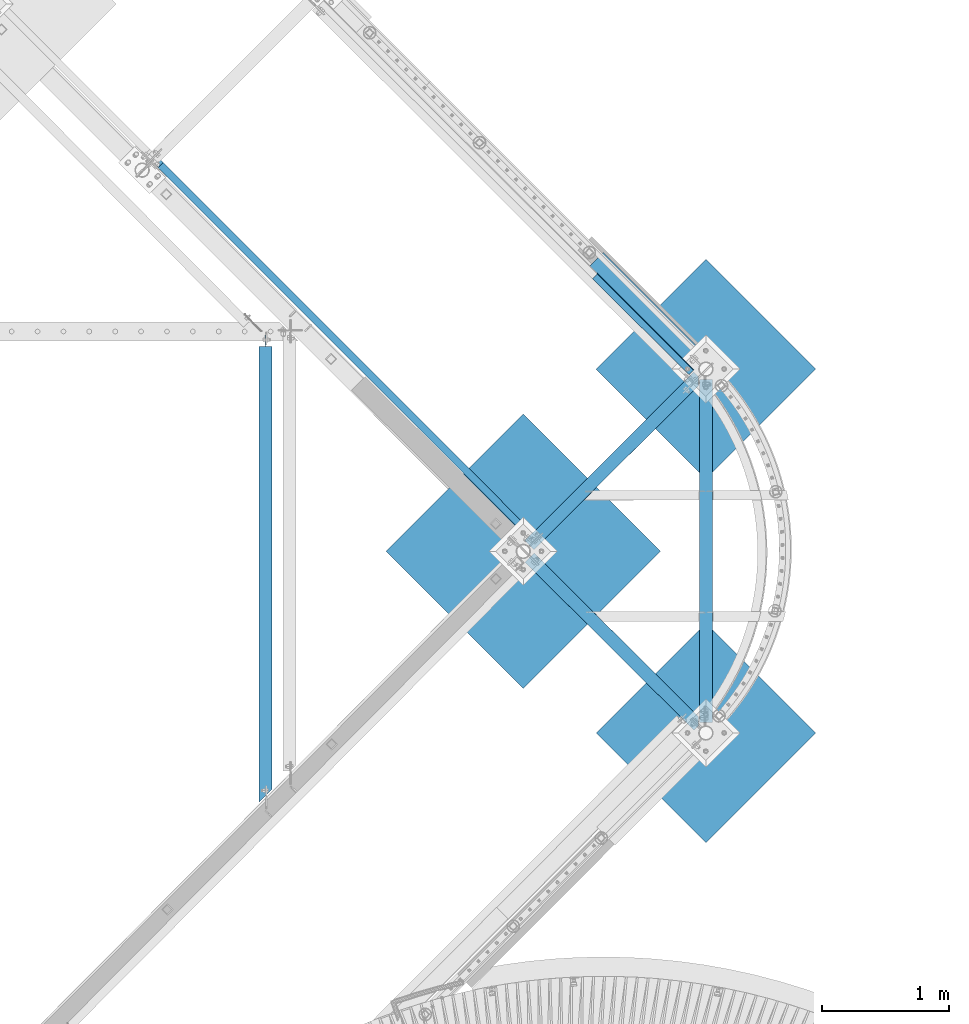
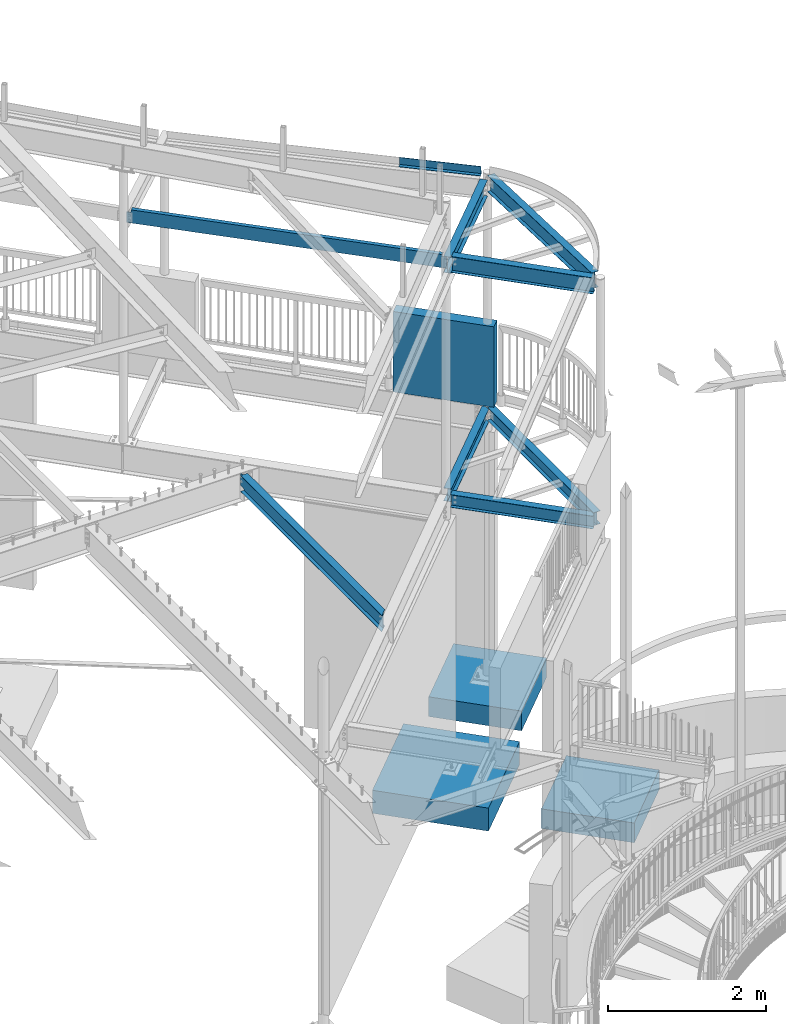
# One storey, part 370 of 975: 13 beams.
"""IFC2X3 building model written with IfcOpenShell, lengths in millimetres."""

from ifc_helpers import new_model, si_unit, frame, origin_with_axes, place, context, subcontext, project, spatial, faceted_brep, material, type_object, element, save


model = new_model("IFC2X3")

# Units and contexts
model_context = context("Model", 3, precision=1e-05, world=origin_with_axes())
body_context = subcontext(model_context, "Body", "Model", "MODEL_VIEW")
ifc_project = project(units=[si_unit("LENGTHUNIT", "METRE", prefix="MILLI"), si_unit("AREAUNIT", "SQUARE_METRE"), si_unit("VOLUMEUNIT", "CUBIC_METRE"), si_unit("MASSUNIT", "GRAM", prefix="KILO"), si_unit("TIMEUNIT", "SECOND"), si_unit("PLANEANGLEUNIT", "RADIAN"), si_unit("SOLIDANGLEUNIT", "STERADIAN"), si_unit("THERMODYNAMICTEMPERATUREUNIT", "DEGREE_CELSIUS"), si_unit("LUMINOUSINTENSITYUNIT", "LUMEN")], contexts=[model_context])

# Site, building, storey
site_placement = place(None, origin_with_axes())
site = spatial("IfcSite", under=ifc_project, at=site_placement, CompositionType="ELEMENT")
building_placement = place(site_placement, origin_with_axes())
building = spatial("IfcBuilding", under=site, at=building_placement, Name="Undefined", CompositionType="ELEMENT")
storey_placement = place(building_placement, origin_with_axes())
storey = spatial("IfcBuildingStorey", under=building, at=storey_placement, Name="Undefined", CompositionType="ELEMENT", Elevation=0.0)

# Beams
ifc_material_1 = material(Name="STEEL/A36")
beam_type_1 = type_object("IfcBeamType", Name="C8X11.5", PredefinedType="NOTDEFINED")
beam_1_placement = place(storey_placement, frame((31205.9021724707, 14750.0647133763, 7366.00732123605), z_axis=(0.00848710718288203, -0.00849015018294813, -0.999927940584489), x_axis=(0.706929084127508, -0.707182548127554, 0.0120047340021652)))
element("IfcBeam", 1, at=beam_1_placement, inside=storey, type_object=beam_type_1, material=ifc_material_1, Name="BEAM", ObjectType="C8X11.5", context=body_context, shape_type="Brep", body=[
    faceted_brep([(14.5851371900117, 22.2249999999367, -63.0535958146374), (14.5958389705302, 28.5749999999425, -63.0535958144128), (63.0111703936491, 28.5749999999061, -62.4723424049889), (63.0004686131215, 22.224999999893, -62.4723424052208), (67.8825119353241, 28.5749999998916, -63.3806587867875), (67.8718101547984, 22.2249999998894, -63.3806587870204), (72.0354465572545, 28.574999999888, -66.0840127549527), (72.0247447767269, 22.2249999998821, -66.0840127551864), (74.8377276096962, 28.574999999877, -70.1708431737961), (74.8270258291686, 22.2249999998712, -70.1708431740281), (75.8627332051528, 28.5749999998734, -75.018967159257), (75.8520314246252, 22.2249999998639, -75.018967159489), (76.1818544297275, 28.5749999998407, -101.600000000039), (76.0855384048937, -28.5750000002299, -101.600000000039), (76.028338868422, -28.5750000002226, -96.8355950000378), (76.0123463658147, 22.2249999998457, -88.3723150000351), (12.6190739055528, 28.5750000001535, 101.600000000019), (12.5227578808281, -28.5749999999098, 101.600000000019), (4213.9969958336, -28.5750000033477, 101.599999999028), (4213.94744551026, 28.5749999967193, 101.599999999029), (12.5799574173052, -28.5749999999171, 96.8355950000177), (4214.05419537008, -28.5750000033586, 96.8355949990273), (12.7671784084177, 22.2250000001332, 88.3723150000169), (4214.11175738513, 22.2249999966953, 88.3723149990265), (4216.03259688175, 22.2249999964843, -71.6229903119474), (4216.02709129025, 28.5749999964937, -71.6229903103012), (4167.61731592971, 22.2249999965206, -72.2042443293622), (4167.6118103382, 28.5749999965301, -72.2042443277105), (4162.76919013488, 22.2249999965206, -73.2292485299204), (4162.76368454337, 28.5749999965301, -73.2292485282687), (4158.68235821508, 22.2249999965243, -76.0315256539234), (4158.67685262357, 28.5749999965337, -76.0315256522726), (4155.9790032829, 22.224999996517, -80.1844544119476), (4155.97349769139, 28.5749999965265, -80.1844544102969), (4155.07068662078, 22.2249999965061, -85.0557890469763), (4155.06518102927, 28.5749999965228, -85.0557890453256), (4155.11050350188, 22.2249999965097, -88.3723150009964), (4155.2561549807, -28.5750000035623, -96.8355950009991), (4155.31335451717, -28.5750000035696, -101.600000001001), (4155.26380419377, 28.5749999964974, -101.600000001)], [[[0, 1, 2, 3]], [[3, 2, 4, 5]], [[5, 4, 6, 7]], [[7, 6, 8, 9]], [[9, 8, 10, 11]], [[12, 13, 14, 15, 11, 10]], [[16, 17, 18, 19]], [[17, 20, 21, 18]], [[20, 22, 23, 21]], [[19, 18, 21, 23, 24, 25]], [[24, 26, 27, 25]], [[28, 29, 27, 26]], [[30, 31, 29, 28]], [[32, 33, 31, 30]], [[34, 35, 33, 32]], [[36, 37, 38, 39, 35, 34]], [[8, 6, 4, 2, 1, 16, 19, 25, 27, 29, 31, 33, 35, 39, 12, 10]], [[22, 20, 17, 16, 1, 0]], [[36, 34, 32, 30, 28, 26, 24, 23, 22, 0, 3, 5, 7, 9, 11, 15]], [[37, 36, 15, 14]], [[38, 37, 14, 13]], [[39, 38, 13, 12]]]),
])
beam_type_2 = type_object("IfcBeamType", PredefinedType="NOTDEFINED")
beam_2_placement = place(storey_placement, frame((35026.524474338, 13429.3034844276, 7492.95806457701), z_axis=(0.707081767936129, -0.705506028102773, 0.047923040001313), x_axis=(0.706317608795658, 0.70789507379521, -1.28799999784181e-06)))
element("IfcBeam", 2, at=beam_2_placement, inside=storey, type_object=beam_type_2, material=ifc_material_1, Name="DECK_EDGE", context=body_context, shape_type="Brep", body=[
    faceted_brep([(7.71251507103443e-10, -3.17500000010841, -534.987499999572), (-6.62112142890692e-10, -3.17499999989013, 534.987499999577), (-7.71251507103443e-10, 3.17500000011114, 534.987499999579), (6.69388100504875e-10, 3.17499999989377, -534.987499999572), (51.3282235300721, 3.17500000094242, 534.987499999592), (51.3282235311635, 3.17500000072505, -534.987499999563), (57.6782232918777, -3.17499999917436, -534.987499999559), (57.6782232907935, -3.17499999895608, 534.987499999595), (51.3282275979072, 111.125003185655, 534.987499999528), (51.3282275993188, 111.125003185086, -534.987499999623), (57.6782275979131, 111.125002946355, 534.987499999526), (57.6782275993319, 111.125002945787, -534.987499999623)], [[[0, 1, 2, 3]], [[3, 2, 4, 5]], [[1, 0, 6, 7]], [[5, 4, 8, 9]], [[4, 2, 1, 7, 10, 8]], [[7, 6, 11, 10]], [[6, 0, 3, 5, 9, 11]], [[10, 11, 9, 8]]]),
])
ifc_material_2 = material(Name="CONCRETE/5000")
beam_type_3 = type_object("IfcBeamType", PredefinedType="NOTDEFINED")
beam_3_placement = place(storey_placement, frame((34677.1916348473, 13958.0288728638, 4559.3), z_axis=(0.0, 0.0, 1.0), x_axis=(0.707901544041155, -0.706311124041062, 0.0)))
element("IfcBeam", 3, at=beam_3_placement, inside=storey, type_object=beam_type_3, material=ifc_material_2, Name="LOW WALL", context=body_context, shape_type="Brep", body=[
    faceted_brep([(1.0550138540566e-10, 76.1999999999316, -622.3), (1.0550138540566e-10, 76.1999999999316, 622.3), (1320.79999999791, 76.1999999990949, 622.3), (1320.79999999791, 76.1999999990949, -622.3), (-1.01863406598568e-10, -76.1999999999243, 622.3), (1320.7999999978, -76.2000000010521, 622.3), (-1.01863406598568e-10, -76.1999999999243, -622.3), (1320.7999999978, -76.2000000010521, -622.3)], [[[0, 1, 2, 3]], [[1, 4, 5, 2]], [[4, 6, 7, 5]], [[6, 0, 3, 7]], [[5, 7, 3, 2]], [[6, 4, 1, 0]]]),
])
ifc_material_3 = material(Name="STEEL/A992")
beam_type_4 = type_object("IfcBeamType", Name="W8X10", PredefinedType="NOTDEFINED")
beam_4_placement = place(storey_placement, frame((35537.7749999864, 10240.9624999995, 3836.9875), z_axis=(0.0, 0.0, 1.0), x_axis=(0.0, 1.0, 0.0)))
element("IfcBeam", 4, at=beam_4_placement, inside=storey, type_object=beam_type_4, material=ifc_material_3, Name="FRAME", ObjectType="W8X10", context=body_context, shape_type="Brep", body=[
    faceted_brep([(81.8463886655572, -50.8000000000029, -100.0125), (81.8463886655572, 50.8000000000029, -100.0125), (2774.06611160423, 50.8000000000029, -100.0125), (2774.06611160423, -50.8000000000029, -100.0125), (81.8463886655572, -50.8000000000029, -95.25), (81.8463886655572, -2.38124999999854, -95.25), (81.8463886655572, -2.38124999999854, 95.25), (81.8463886655572, -50.8000000000029, 95.25), (81.8463886655572, -50.8000000000029, 100.0125), (81.8463886655572, 50.8000000000029, 100.0125), (81.8463886655572, 50.8000000000029, 95.25), (81.8463886655572, 2.38124999999854, 95.25), (81.8463886655572, 2.38124999999854, -95.25), (81.8463886655572, 50.8000000000029, -95.25), (2774.06611160423, -50.8000000000029, -95.25), (2774.06611160423, -2.38124999999854, -95.25), (2774.06611160423, -2.38124999999854, 95.25), (2774.06611160423, -50.8000000000029, 95.25), (2774.06611160423, -50.8000000000029, 100.0125), (2774.06611160423, 50.8000000000029, 100.0125), (2774.06611160423, 50.8000000000029, 95.25), (2774.06611160423, 2.38124999999854, 95.25), (2774.06611160423, 2.38124999999854, -95.25), (2774.06611160423, 50.8000000000029, -95.25)], [[[0, 1, 2, 3]], [[0, 4, 5, 6, 7, 8, 9, 10, 11, 12, 13, 1]], [[5, 4, 14, 15]], [[6, 5, 15, 16]], [[7, 6, 16, 17]], [[8, 7, 17, 18]], [[9, 8, 18, 19]], [[10, 9, 19, 20]], [[11, 10, 20, 21]], [[12, 11, 21, 22]], [[13, 12, 22, 23]], [[1, 13, 23, 2]], [[22, 21, 20, 19, 18, 17, 16, 15, 14, 3, 2, 23]], [[4, 0, 3, 14]]]),
])
beam_5_placement = place(storey_placement, frame((34104.2134777855, 11666.4883674129, 3836.9875), z_axis=(0.0, 0.0, 1.0), x_axis=(0.709091351882085, -0.705116624882748, 0.0)))
element("IfcBeam", 5, at=beam_5_placement, inside=storey, type_object=beam_type_4, material=ifc_material_3, Name="BEAM", ObjectType="W8X10", context=body_context, shape_type="Brep", body=[
    faceted_brep([(69.9929970150533, -50.7999999999774, -100.0125), (69.9929970150715, -50.7999999999738, -95.25), (69.9929970148678, -2.38124999986758, -95.25), (69.9929970153225, -2.38124999986758, 95.25), (69.9929970155226, -50.7999999999738, 95.25), (69.9929970155335, -50.7999999999738, 100.0125), (69.992997015117, 50.8000000002503, 100.0125), (69.9929970151061, 50.8000000002539, 95.25), (69.9929970153025, 2.38125000014406, 95.25), (69.9929970148514, 2.38125000014406, -95.25), (69.9929970146532, 50.8000000002539, -95.25), (69.9929970146441, 50.8000000002503, -100.0125), (1939.16326913358, -50.7999999963831, -100.0125), (1939.16326913358, -50.7999999963831, -95.25), (1939.16326913377, -2.38124999627689, -95.25), (1939.16326913377, -2.38124999627689, 95.25), (1939.16326913358, -50.7999999963831, 95.25), (1939.16326913358, -50.7999999963831, 100.0125), (1939.16326913378, 4.96838765684515e-08, 100.0125), (1888.36326922199, 50.80000000375, 100.0125), (1888.36326922199, 50.80000000375, 95.25), (1936.78201918172, 2.38125000373475, 95.25), (1936.78201918172, 2.38125000373475, -95.25), (1888.36326922199, 50.80000000375, -95.25), (1888.36326922199, 50.80000000375, -100.0125), (1939.16326913378, 4.96838765684515e-08, -100.0125)], [[[0, 1, 2, 3, 4, 5, 6, 7, 8, 9, 10, 11]], [[1, 0, 12, 13]], [[2, 1, 13, 14]], [[3, 2, 14, 15]], [[4, 3, 15, 16]], [[5, 4, 16, 17]], [[6, 5, 17, 18, 19]], [[7, 6, 19, 20]], [[8, 7, 20, 21]], [[9, 8, 21, 22]], [[10, 9, 22, 23]], [[11, 10, 23, 24]], [[12, 0, 11, 24, 25]], [[17, 16, 15, 14, 13, 12, 25, 18]], [[24, 23, 22, 21, 20, 19, 18, 25]]]),
])
beam_6_placement = place(storey_placement, frame((34104.2134777855, 11666.4883674129, 3836.9875), z_axis=(0.0, 0.0, 1.0), x_axis=(0.707890224195014, 0.706322469194583, 0.0)))
element("IfcBeam", 6, at=beam_6_placement, inside=storey, type_object=beam_type_4, material=ifc_material_3, Name="BEAM", ObjectType="W8X10", context=body_context, shape_type="Brep", body=[
    faceted_brep([(69.9093838737463, 2.38125000011132, 95.25), (69.9093838738081, 50.8000000001666, 95.25), (1942.57840328311, 50.8000000031479, 95.25), (1942.57840328305, 2.38125000309446, 95.25), (69.9093838737463, 2.38125000011132, -95.25), (1942.57840328305, 2.38125000309446, -95.25), (69.9093838738081, 50.8000000001666, -95.25), (1942.57840328311, 50.8000000031479, -95.25), (69.9093838738081, 50.8000000001666, -100.0125), (1942.57840328311, 50.8000000031479, -100.0125), (69.9093838736735, -50.7999999999429, -100.0125), (69.9093838736735, -50.7999999999429, -95.25), (69.9093838737354, -2.38124999988941, -95.25), (69.9093838737354, -2.38124999988941, 95.25), (69.9093838736735, -50.7999999999429, 95.25), (69.9093838736735, -50.7999999999429, 100.0125), (69.9093838738081, 50.8000000001666, 100.0125), (1942.57840328311, 50.8000000031479, 100.0125), (1942.57840328304, 2.2313543013297e-08, 100.0125), (1942.57840328304, 2.2313543013297e-08, -100.0125), (1891.77840328404, -50.7999999970489, -100.0125), (1891.77840328404, -50.7999999970489, -95.25), (1940.19715326477, -2.38124999691536, -95.25), (1940.19715326477, -2.38124999691536, 95.25), (1891.77840328404, -50.7999999970489, 95.25), (1891.77840328404, -50.7999999970489, 100.0125)], [[[0, 1, 2, 3]], [[4, 0, 3, 5]], [[6, 4, 5, 7]], [[8, 6, 7, 9]], [[10, 11, 12, 13, 14, 15, 16, 1, 0, 4, 6, 8]], [[1, 16, 17, 2]], [[9, 7, 5, 3, 2, 17, 18, 19]], [[10, 8, 9, 19, 20]], [[11, 10, 20, 21]], [[12, 11, 21, 22]], [[13, 12, 22, 23]], [[14, 13, 23, 24]], [[15, 14, 24, 25]], [[17, 16, 15, 25, 18]], [[24, 23, 22, 21, 20, 19, 18, 25]]]),
])
beam_type_5 = type_object("IfcBeamType", Name="W10X12", PredefinedType="NOTDEFINED")
beam_7_placement = place(storey_placement, frame((34104.2625004805, 11666.5374995221, 7494.58749999992), z_axis=(0.0, 0.0, 1.0), x_axis=(0.709067143694186, -0.705140968695883, 0.0)))
element("IfcBeam", 7, at=beam_7_placement, inside=storey, type_object=beam_type_5, material=ifc_material_3, Name="BEAM", ObjectType="W10X12", context=body_context, shape_type="Brep", body=[
    faceted_brep([(82.5251009402837, -50.7999999999192, -125.4125), (82.5251009405456, 50.8000000002103, -125.4125), (1939.16284790769, 50.8000000033971, -125.4125), (1939.16284790742, -50.7999999967324, -125.4125), (82.5251009402837, -50.7999999999192, -120.65), (82.5251009404074, -2.38124999986394, -120.65), (82.5251009404074, -2.38124999986394, 120.65), (82.5251009402837, -50.7999999999192, 120.65), (82.5251009402837, -50.7999999999192, 125.4125), (82.5251009405456, 50.8000000002103, 125.4125), (82.5251009405456, 50.8000000002103, 120.65), (82.5251009404219, 2.38125000014406, 120.65), (82.5251009404219, 2.38125000014406, -120.65), (82.5251009405456, 50.8000000002103, -120.65), (1939.16284790742, -50.7999999967324, -120.65), (1939.16284790755, -2.38124999667343, -120.65), (1939.16284790755, -2.38124999667343, 120.65), (1939.16284790742, -50.7999999967324, 120.65), (1939.16284790742, -50.7999999967324, 125.4125), (1939.16284790769, 50.8000000033971, 125.4125), (1939.16284790769, 50.8000000033971, 120.65), (1939.16284790756, 2.38125000333093, 120.65), (1939.16284790756, 2.38125000333093, -120.65), (1939.16284790769, 50.8000000033971, -120.65)], [[[0, 1, 2, 3]], [[0, 4, 5, 6, 7, 8, 9, 10, 11, 12, 13, 1]], [[5, 4, 14, 15]], [[6, 5, 15, 16]], [[7, 6, 16, 17]], [[8, 7, 17, 18]], [[9, 8, 18, 19]], [[10, 9, 19, 20]], [[11, 10, 20, 21]], [[12, 11, 21, 22]], [[13, 12, 22, 23]], [[1, 13, 23, 2]], [[22, 21, 20, 19, 18, 17, 16, 15, 14, 3, 2, 23]], [[4, 0, 3, 14]]]),
])
beam_8_placement = place(storey_placement, frame((34104.2625000152, 11666.5375000152, 7392.9875), z_axis=(0.0, 0.0, 1.0), x_axis=(0.707846168211467, 0.706366620211023, 0.0)))
element("IfcBeam", 8, at=beam_8_placement, inside=storey, type_object=beam_type_5, material=ifc_material_3, Name="BEAM", ObjectType="W10X12", context=body_context, shape_type="Brep", body=[
    faceted_brep([(1821.79569881341, 2.38125000038781, -120.65), (1821.79569881342, 2.3812492416655, -125.4125), (1821.79569881361, 50.8000000003212, -125.4125), (1821.79569881361, 50.8000000003212, -120.65), (1840.92832630048, 2.38124924172189, -120.65), (1840.92832683544, 2.38124924171643, -125.4125), (69.8405629692897, -50.7999999999247, -125.4125), (69.8405629692897, -50.7999999999247, -120.65), (69.8405629694098, -2.38124999998763, -120.65), (69.8405629694098, -2.38124999998763, 120.65), (69.8405629692897, -50.7999999999247, 120.65), (69.8405629692897, -50.7999999999247, 125.4125), (69.840562969548, 50.7999999999465, 125.4125), (69.840562969548, 50.7999999999465, 120.65), (69.8405629694244, 2.381250000004, 120.65), (69.8405629694244, 2.381250000004, -120.65), (69.840562969548, 50.7999999999465, -120.65), (69.840562969548, 50.7999999999465, -125.4125), (1840.9283268353, -50.7999999995391, -125.4125), (1840.9283268353, -50.7999999995391, -120.65), (1840.92832683542, -2.38124999960382, -120.65), (1840.92832683542, -2.38124999960382, 120.65), (1840.9283268353, -50.7999999995391, 120.65), (1840.9283268353, -50.7999999995391, 125.4125), (1840.92832683556, 50.8000000003249, 125.4125), (1840.92832683556, 50.8000000003249, 120.65), (1840.92832683544, 2.38125000039145, 120.65), (1840.92832683544, 2.38125000039145, -77.7875000000049)], [[[0, 1, 2, 3]], [[4, 5, 1, 0]], [[6, 7, 8, 9, 10, 11, 12, 13, 14, 15, 16, 17]], [[7, 6, 18, 19]], [[8, 7, 19, 20]], [[9, 8, 20, 21]], [[10, 9, 21, 22]], [[11, 10, 22, 23]], [[12, 11, 23, 24]], [[13, 12, 24, 25]], [[14, 13, 25, 26]], [[0, 15, 14, 26, 27, 4]], [[16, 15, 0, 3]], [[17, 16, 3, 2]], [[18, 6, 17, 2, 1, 5]], [[27, 26, 25, 24, 23, 22, 21, 20, 19, 18, 5, 4]]]),
])
beam_9_placement = place(storey_placement, frame((35537.775, 10236.5037308524, 7494.66678599055), z_axis=(0.0, 0.0355528290119237, 0.999367798335152), x_axis=(0.0, 0.999367798335152, -0.0355528290119233)))
element("IfcBeam", 9, at=beam_9_placement, inside=storey, type_object=beam_type_5, material=ifc_material_3, Name="FRAME", ObjectType="W10X12", context=body_context, shape_type="Brep", body=[
    faceted_brep([(141.653480547368, -50.8000000000029, -125.412499999959), (141.653480547368, 50.8000000000029, -125.412499999959), (2784.74416981815, 50.8000000000029, -125.412500000133), (2784.74416981815, -50.8000000000029, -125.412500000133), (141.484053086871, -50.8000000000029, -120.649999999961), (141.484053086871, -2.38124999999854, -120.649999999961), (132.899728421733, -2.38124999999854, 120.649999999944), (132.899728421733, -50.8000000000029, 120.649999999944), (132.730300961237, -50.8000000000029, 125.412499999942), (132.730300961237, 50.8000000000029, 125.412499999942), (132.899728421733, 50.8000000000029, 120.649999999944), (132.899728421733, 2.38124999999854, 120.649999999944), (141.484053086871, 2.38124999999854, -120.649999999961), (141.484053086871, 50.8000000000029, -120.649999999961), (2784.57474235766, -50.8000000000029, -120.650000000136), (2784.57474235766, -2.38124999999854, -120.650000000136), (2775.99041769252, -2.38124999999854, 120.64999999977), (2775.99041769252, -50.8000000000029, 120.64999999977), (2775.82099023202, -50.8000000000029, 125.412499999768), (2775.82099023202, 50.8000000000029, 125.412499999768), (2775.99041769252, 50.8000000000029, 120.64999999977), (2775.99041769252, 2.38124999999854, 120.64999999977), (2784.57474235766, 2.38124999999854, -120.650000000136), (2784.57474235766, 50.8000000000029, -120.650000000136)], [[[0, 1, 2, 3]], [[0, 4, 5, 6, 7, 8, 9, 10, 11, 12, 13, 1]], [[5, 4, 14, 15]], [[6, 5, 15, 16]], [[7, 6, 16, 17]], [[8, 7, 17, 18]], [[9, 8, 18, 19]], [[10, 9, 19, 20]], [[11, 10, 20, 21]], [[12, 11, 21, 22]], [[13, 12, 22, 23]], [[1, 13, 23, 2]], [[22, 21, 20, 19, 18, 17, 16, 15, 14, 3, 2, 23]], [[4, 0, 3, 14]]]),
])
beam_10_placement = place(storey_placement, frame((32080.2, 9631.60935494588, 3811.5875), z_axis=(0.0, 0.0, 1.0), x_axis=(0.0, 1.0, 0.0)))
element("IfcBeam", 10, at=beam_10_placement, inside=storey, type_object=beam_type_5, material=ifc_material_3, Name="BEAM", ObjectType="W10X12", context=body_context, shape_type="Brep", body=[
    faceted_brep([(3642.27189505412, -2.38124999999854, -120.65), (3642.27189505412, -50.7999999999993, -120.65), (3642.27189505412, -50.7999999999993, -125.4125), (3642.27189505412, 50.7999999999993, -125.4125), (3642.27189505412, 50.7999999999993, -120.65), (3642.27189505412, 2.38124999999854, -120.65), (3642.27189505412, 2.38124999999854, -112.712499809265), (3642.27189505412, -2.38124999999854, -112.712499809265), (3643.23862497671, 2.38124999999854, -107.852420291219), (3643.23862497671, -2.38124999999854, -107.852420291219), (3645.99163887719, 2.38124999999854, -103.732243823066), (3645.99163887719, -2.38124999999854, -103.732243823066), (3650.11181534534, 2.38124999999854, -100.979229922588), (3650.11181534534, -2.38124999999854, -100.979229922588), (3654.97189486339, 2.38124999999854, -100.0125), (3654.97189486339, -2.38124999999854, -100.0125), (3731.17189505412, -2.38124999999854, -100.0125), (3731.17189505412, 2.38124999999854, -100.0125), (114.663068826216, 2.38124999999854, 120.65), (65.9843954877088, 50.7999999999993, 120.65), (3642.27189505412, 50.7999999999993, 120.65), (3642.27189505412, 2.38124999999854, 120.65), (168.129808394739, -50.7999999999993, -125.4125), (168.129808394739, -50.7999999999993, -120.65), (119.451135056232, -2.38124999999854, -120.65), (119.451135056232, -2.38124999999854, 120.65), (168.129808394739, -50.7999999999993, 120.65), (168.129808394739, -50.7999999999993, 125.4125), (65.9843954877088, 50.7999999999993, 125.4125), (114.663068826216, 2.38124999999854, -120.65), (65.9843954877088, 50.7999999999993, -120.65), (65.9843954877088, 50.7999999999993, -125.4125), (3642.27189505412, -2.38124999999854, 120.65), (3642.27189505412, -50.7999999999993, 120.65), (3642.27189505412, -50.7999999999993, 125.4125), (3642.27189505412, 50.7999999999993, 125.4125), (3642.27189505412, -2.38124999999854, 112.712499809265), (3642.27189505412, 2.38124999999854, 112.712499809265), (3643.23862497671, -2.38124999999854, 107.85242029122), (3643.23862497671, 2.38124999999854, 107.85242029122), (3645.99163887719, -2.38124999999854, 103.732243823066), (3645.99163887719, 2.38124999999854, 103.732243823066), (3650.11181534534, -2.38124999999854, 100.979229922588), (3650.11181534534, 2.38124999999854, 100.979229922588), (3654.97189486339, -2.38124999999854, 100.0125), (3654.97189486339, 2.38124999999854, 100.0125), (3731.17189505412, -2.38124999999854, 100.0125), (3731.17189505412, 2.38124999999854, 100.0125)], [[[0, 1, 2, 3, 4, 5, 6, 7]], [[7, 6, 8, 9]], [[9, 8, 10, 11]], [[11, 10, 12, 13]], [[13, 12, 14, 15]], [[16, 15, 14, 17]], [[18, 19, 20, 21]], [[22, 23, 24, 25, 26, 27, 28, 19, 18, 29, 30, 31]], [[26, 25, 32, 33]], [[27, 26, 33, 34]], [[28, 27, 34, 35]], [[19, 28, 35, 20]], [[34, 33, 32, 36, 37, 21, 20, 35]], [[38, 39, 37, 36]], [[40, 41, 39, 38]], [[42, 43, 41, 40]], [[44, 45, 43, 42]], [[46, 47, 45, 44]], [[47, 46, 16, 17]], [[12, 10, 8, 6, 5, 29, 18, 21, 37, 39, 41, 43, 45, 47, 17, 14]], [[30, 29, 5, 4]], [[31, 30, 4, 3]], [[22, 31, 3, 2]], [[23, 22, 2, 1]], [[24, 23, 1, 0]], [[46, 44, 42, 40, 38, 36, 32, 25, 24, 0, 7, 9, 11, 13, 15, 16]]]),
])
beam_type_6 = type_object("IfcBeamType", PredefinedType="NOTDEFINED")
beam_11_placement = place(storey_placement, frame((33565.4471327365, 11127.7221327309, -482.6), z_axis=(0.0, 0.0, -1.0), x_axis=(0.707106781186548, 0.707106781186548, 0.0)))
element("IfcBeam", 11, at=beam_11_placement, inside=storey, type_object=beam_type_6, material=ifc_material_2, Name="FOOTING", context=body_context, shape_type="Brep", body=[
    faceted_brep([(4.8748916015029e-10, 762.000000001049, -177.8), (4.8748916015029e-10, 762.000000001049, 177.8), (1524.00000000259, 762.000000000074, 177.8), (1524.00000000259, 762.000000000074, -177.8), (-4.80213202536106e-10, -762.000000001047, 177.8), (1524.00000000162, -762.00000000202, 177.8), (-4.80213202536106e-10, -762.000000001047, -177.8), (1524.00000000162, -762.00000000202, -177.8)], [[[0, 1, 2, 3]], [[1, 4, 5, 2]], [[4, 6, 7, 5]], [[6, 0, 3, 7]], [[5, 7, 3, 2]], [[6, 4, 1, 0]]]),
])
beam_type_7 = type_object("IfcBeamType", PredefinedType="NOTDEFINED")
for number, where, z_axis, x_axis, name in (
    (12, (35106.7226952161, 12665.8227098173, -457.2), (0.0, 0.0, -1.0), (0.707106781186548, 0.707106781186548, 0.0), "FOOTING"),
    (13, (35106.7226952265, 9809.91020982771, -457.2), (0.0, 0.0, -1.0), (0.707106781186548, 0.707106781186548, 0.0), "FOOTING"),
):
    element("IfcBeam", number, at=place(storey_placement, frame(where, z_axis=z_axis, x_axis=x_axis)), inside=storey, type_object=beam_type_7, material=ifc_material_2, Name=name, context=body_context, shape_type="Brep", body=[
        faceted_brep([(1.62981450557709e-09, 609.600000000892, -152.4), (1.62981450557709e-09, 609.600000000892, 152.4), (1219.20000000183, 609.600000002347, 152.4), (1219.20000000183, 609.600000002347, -152.4), (-1.61526259034872e-09, -609.600000000886, 152.4), (1219.19999999859, -609.599999999426, 152.4), (-1.61526259034872e-09, -609.600000000886, -152.4), (1219.19999999859, -609.599999999426, -152.4)], [[[0, 1, 2, 3]], [[1, 4, 5, 2]], [[4, 6, 7, 5]], [[6, 0, 3, 7]], [[5, 7, 3, 2]], [[6, 4, 1, 0]]]),
    ])

save(model, "model.ifc")
